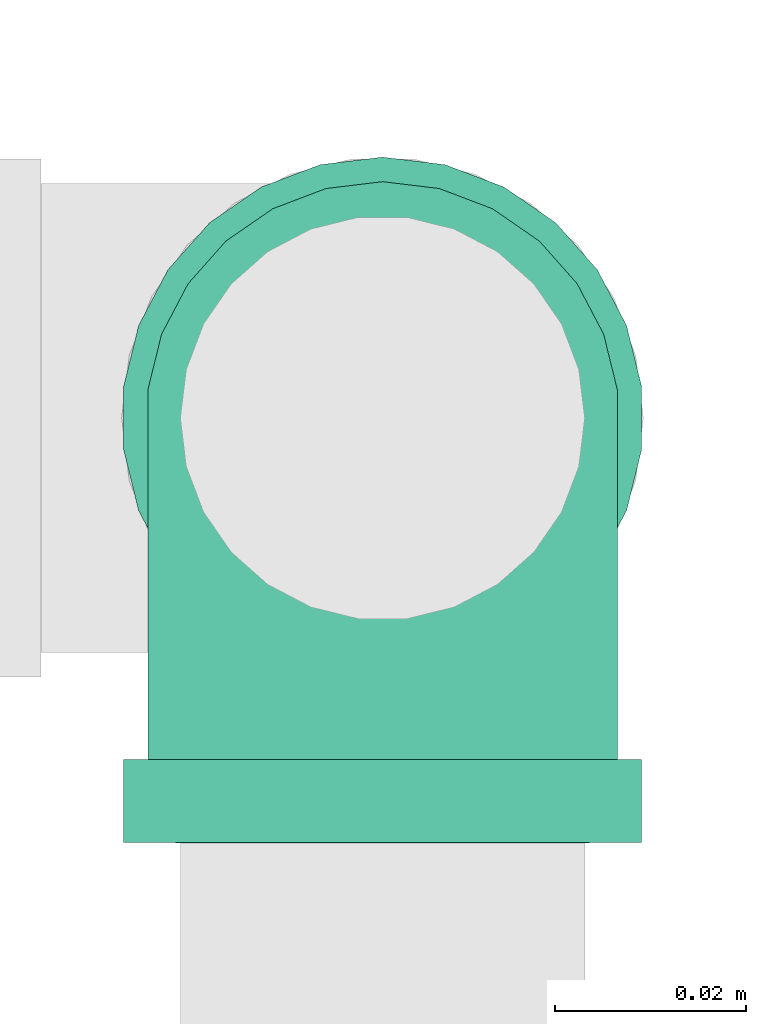
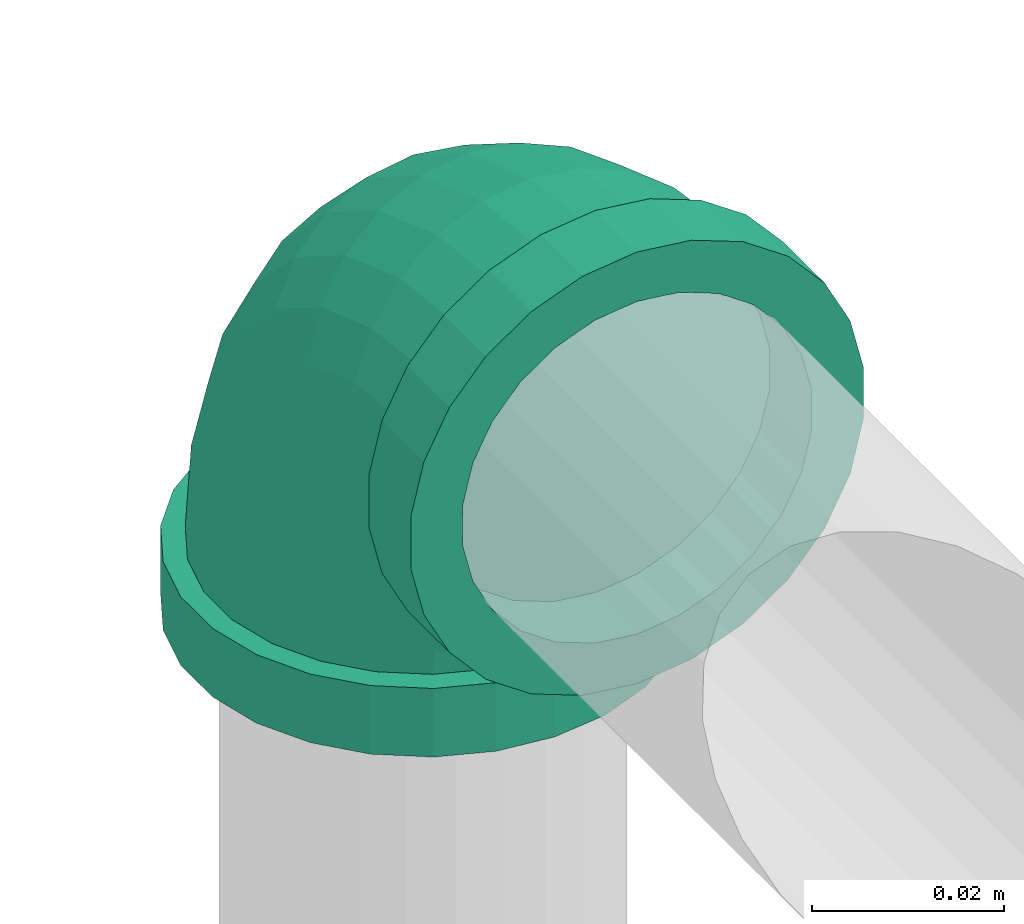
# One storey, part 5 of 7: 1 pipe fitting.
"""IFC4 building model written with IfcOpenShell, lengths in millimetres."""

from ifc_helpers import new_model, entity, si_unit, converted_unit, derived_unit, direction, frame, origin, place, context, subcontext, project, spatial, source, transform, mapped, type_object, type_shapes, element, save


model = new_model("IFC4")

# Units and contexts
model_context = context("Model", 3, precision=0.01, world=origin(), true_north=direction((6.12303176911189e-17, 1.0)))
body_context = subcontext(model_context, "Body", "Model", "MODEL_VIEW")
ifc_project = project(units=[si_unit("LENGTHUNIT", "METRE", prefix="MILLI"), si_unit("AREAUNIT", "SQUARE_METRE"), si_unit("VOLUMEUNIT", "CUBIC_METRE"), converted_unit("PLANEANGLEUNIT", "DEGREE", entity("IfcRatioMeasure", 0.0174532925199433), si_unit("PLANEANGLEUNIT", "RADIAN"), dimensions=[0, 0, 0, 0, 0, 0, 0]), si_unit("MASSUNIT", "GRAM", prefix="KILO"), derived_unit("MASSDENSITYUNIT", [(si_unit("MASSUNIT", "GRAM", prefix="KILO"), 1), (si_unit("LENGTHUNIT", "METRE"), -3)]), derived_unit("MOMENTOFINERTIAUNIT", [(si_unit("LENGTHUNIT", "METRE"), 4)]), si_unit("TIMEUNIT", "SECOND"), si_unit("FREQUENCYUNIT", "HERTZ"), si_unit("THERMODYNAMICTEMPERATUREUNIT", "DEGREE_CELSIUS"), derived_unit("THERMALTRANSMITTANCEUNIT", [(si_unit("MASSUNIT", "GRAM", prefix="KILO"), 1), (si_unit("THERMODYNAMICTEMPERATUREUNIT", "KELVIN"), -1), (si_unit("TIMEUNIT", "SECOND"), -3)]), derived_unit("VOLUMETRICFLOWRATEUNIT", [(si_unit("LENGTHUNIT", "METRE"), 3), (si_unit("TIMEUNIT", "SECOND"), -1)]), si_unit("ELECTRICCURRENTUNIT", "AMPERE"), si_unit("ELECTRICVOLTAGEUNIT", "VOLT"), si_unit("POWERUNIT", "WATT"), si_unit("FORCEUNIT", "NEWTON", prefix="KILO"), si_unit("ILLUMINANCEUNIT", "LUX"), si_unit("LUMINOUSFLUXUNIT", "LUMEN"), si_unit("LUMINOUSINTENSITYUNIT", "CANDELA"), derived_unit("USERDEFINED", [(si_unit("MASSUNIT", "GRAM", prefix="KILO"), -1), (si_unit("LENGTHUNIT", "METRE"), -2), (si_unit("TIMEUNIT", "SECOND"), 3), (si_unit("LUMINOUSFLUXUNIT", "LUMEN"), 1)]), derived_unit("LINEARVELOCITYUNIT", [(si_unit("LENGTHUNIT", "METRE"), 1), (si_unit("TIMEUNIT", "SECOND"), -1)]), si_unit("PRESSUREUNIT", "PASCAL"), derived_unit("USERDEFINED", [(si_unit("LENGTHUNIT", "METRE"), -2), (si_unit("MASSUNIT", "GRAM", prefix="KILO"), 1), (si_unit("TIMEUNIT", "SECOND"), -2)]), derived_unit("LINEARFORCEUNIT", [(si_unit("MASSUNIT", "GRAM", prefix="KILO"), 1), (si_unit("LENGTHUNIT", "METRE"), 1), (si_unit("TIMEUNIT", "SECOND"), -2), (si_unit("LENGTHUNIT", "METRE"), -1)]), derived_unit("PLANARFORCEUNIT", [(si_unit("MASSUNIT", "GRAM", prefix="KILO"), 1), (si_unit("LENGTHUNIT", "METRE"), 1), (si_unit("TIMEUNIT", "SECOND"), -2), (si_unit("LENGTHUNIT", "METRE"), -2)])], contexts=[model_context])

# Site, building, storey
site_placement = place(None, origin())
site = spatial("IfcSite", under=ifc_project, at=site_placement, CompositionType="ELEMENT")
building_placement = place(site_placement, origin())
building = spatial("IfcBuilding", under=site, at=building_placement, CompositionType="ELEMENT")
storey_placement = place(building_placement, origin())
storey = spatial("IfcBuildingStorey", under=building, at=storey_placement, Name="Ebene 1", CompositionType="ELEMENT", Elevation=0.0)

# Pipe fitting
pipe_fitting_type = type_object("IfcPipeFittingType", Name="Threaded - Elbow - MI - Class 1:Standard 4", PredefinedType="NOTDEFINED")
cartesian_point_1 = entity("IfcCartesianPoint", [-44.4999999999936, -27.3500000000084, 0.0])
vertex_point_1 = entity("IfcVertexPoint", cartesian_point_1)
cartesian_point_2 = entity("IfcCartesianPoint", [-44.4999999999936, 27.3499999999916, 0.0])
vertex_point_2 = entity("IfcVertexPoint", cartesian_point_2)
cartesian_point_3 = entity("IfcCartesianPoint", [-44.4999999999936, 0.0, 0.0])
ifc_direction_1 = entity("IfcDirection", [-1.0, 0.0, 0.0])
ifc_direction_2 = entity("IfcDirection", [0.0, 1.0, 0.0])
edge_curve_1 = entity("IfcEdgeCurve", vertex_point_1, vertex_point_2, entity("IfcTrimmedCurve", entity("IfcCircle", entity("IfcAxis2Placement3D", cartesian_point_3, ifc_direction_1, ifc_direction_2), 27.35), [cartesian_point_1], [cartesian_point_2], True, "CARTESIAN"), True)
edge_curve_2 = entity("IfcEdgeCurve", vertex_point_2, vertex_point_1, entity("IfcTrimmedCurve", entity("IfcCircle", entity("IfcAxis2Placement3D", cartesian_point_3, ifc_direction_1, ifc_direction_2), 27.35), [cartesian_point_2], [cartesian_point_1], True, "CARTESIAN"), True)
cartesian_point_4 = entity("IfcCartesianPoint", [-44.4999999999936, 21.0819999999918, 0.0])
vertex_point_3 = entity("IfcVertexPoint", cartesian_point_4)
cartesian_point_5 = entity("IfcCartesianPoint", [-44.4999999999936, -21.0820000000082, 0.0])
vertex_point_4 = entity("IfcVertexPoint", cartesian_point_5)
ifc_direction_3 = entity("IfcDirection", [1.0, 0.0, 0.0])
edge_curve_3 = entity("IfcEdgeCurve", vertex_point_3, vertex_point_4, entity("IfcTrimmedCurve", entity("IfcCircle", entity("IfcAxis2Placement3D", cartesian_point_3, ifc_direction_3, ifc_direction_2), 21.082), [cartesian_point_4], [cartesian_point_5], True, "CARTESIAN"), True)
edge_curve_4 = entity("IfcEdgeCurve", vertex_point_4, vertex_point_3, entity("IfcTrimmedCurve", entity("IfcCircle", entity("IfcAxis2Placement3D", cartesian_point_3, ifc_direction_3, ifc_direction_2), 21.082), [cartesian_point_5], [cartesian_point_4], True, "CARTESIAN"), True)
ifc_direction_4 = entity("IfcDirection", [0.0, 0.0, 1.0])
cartesian_point_6 = entity("IfcCartesianPoint", [-35.7999999999934, 27.3499999999916, 0.0])
vertex_point_5 = entity("IfcVertexPoint", cartesian_point_6)
cartesian_point_7 = entity("IfcCartesianPoint", [-35.7999999999934, -27.3500000000084, 0.0])
vertex_point_6 = entity("IfcVertexPoint", cartesian_point_7)
cartesian_point_8 = entity("IfcCartesianPoint", [-35.7999999999934, 0.0, 0.0])
edge_curve_5 = entity("IfcEdgeCurve", vertex_point_5, vertex_point_6, entity("IfcTrimmedCurve", entity("IfcCircle", entity("IfcAxis2Placement3D", cartesian_point_8, ifc_direction_3, ifc_direction_2), 27.35), [cartesian_point_6], [cartesian_point_7], True, "CARTESIAN"), True)
edge_curve_6 = entity("IfcEdgeCurve", vertex_point_6, vertex_point_5, entity("IfcTrimmedCurve", entity("IfcCircle", entity("IfcAxis2Placement3D", cartesian_point_8, ifc_direction_3, ifc_direction_2), 27.35), [cartesian_point_7], [cartesian_point_6], True, "CARTESIAN"), True)
cartesian_point_9 = entity("IfcCartesianPoint", [-35.7999999999934, -24.7800000000084, 0.0])
vertex_point_7 = entity("IfcVertexPoint", cartesian_point_9)
cartesian_point_10 = entity("IfcCartesianPoint", [-35.7999999999934, 24.7799999999916, 0.0])
vertex_point_8 = entity("IfcVertexPoint", cartesian_point_10)
edge_curve_7 = entity("IfcEdgeCurve", vertex_point_7, vertex_point_8, entity("IfcTrimmedCurve", entity("IfcCircle", entity("IfcAxis2Placement3D", cartesian_point_8, ifc_direction_1, ifc_direction_2), 24.78), [cartesian_point_9], [cartesian_point_10], True, "CARTESIAN"), True)
edge_curve_8 = entity("IfcEdgeCurve", vertex_point_8, vertex_point_7, entity("IfcTrimmedCurve", entity("IfcCircle", entity("IfcAxis2Placement3D", cartesian_point_8, ifc_direction_1, ifc_direction_2), 24.78), [cartesian_point_10], [cartesian_point_9], True, "CARTESIAN"), True)
edge_curve_9 = entity("IfcEdgeCurve", vertex_point_1, vertex_point_6, entity("IfcTrimmedCurve", entity("IfcLine", cartesian_point_1, entity("IfcVector", ifc_direction_3, 304.8)), [cartesian_point_1], [cartesian_point_7], True, "CARTESIAN"), True)
edge_curve_10 = entity("IfcEdgeCurve", vertex_point_5, vertex_point_2, entity("IfcTrimmedCurve", entity("IfcLine", cartesian_point_2, entity("IfcVector", ifc_direction_1, 304.8)), [cartesian_point_6], [cartesian_point_2], True, "CARTESIAN"), True)
cartesian_point_11 = entity("IfcCartesianPoint", [-35.7999999999935, 21.0819999999918, 0.0])
vertex_point_9 = entity("IfcVertexPoint", cartesian_point_11)
edge_curve_11 = entity("IfcEdgeCurve", vertex_point_3, vertex_point_9, entity("IfcTrimmedCurve", entity("IfcLine", cartesian_point_11, entity("IfcVector", ifc_direction_3, 304.8)), [cartesian_point_4], [cartesian_point_11], True, "CARTESIAN"), True)
cartesian_point_12 = entity("IfcCartesianPoint", [-35.7999999999934, -21.0820000000082, 0.0])
vertex_point_10 = entity("IfcVertexPoint", cartesian_point_12)
edge_curve_12 = entity("IfcEdgeCurve", vertex_point_9, vertex_point_10, entity("IfcTrimmedCurve", entity("IfcCircle", entity("IfcAxis2Placement3D", cartesian_point_8, ifc_direction_3, ifc_direction_2), 21.082), [cartesian_point_11], [cartesian_point_12], True, "CARTESIAN"), True)
edge_curve_13 = entity("IfcEdgeCurve", vertex_point_10, vertex_point_4, entity("IfcTrimmedCurve", entity("IfcLine", cartesian_point_12, entity("IfcVector", ifc_direction_1, 304.8)), [cartesian_point_12], [cartesian_point_5], True, "CARTESIAN"), True)
cartesian_point_13 = entity("IfcCartesianPoint", [-27.0374999999917, 0.0, 0.0])
edge_curve_14 = entity("IfcEdgeCurve", vertex_point_10, vertex_point_9, entity("IfcTrimmedCurve", entity("IfcCircle", entity("IfcAxis2Placement3D", cartesian_point_8, ifc_direction_3, ifc_direction_2), 21.082), [cartesian_point_12], [cartesian_point_11], True, "CARTESIAN"), True)
cartesian_point_14 = entity("IfcCartesianPoint", [27.386875344551, 35.7717983733246, 0.0])
vertex_point_11 = entity("IfcVertexPoint", cartesian_point_14)
cartesian_point_15 = entity("IfcCartesianPoint", [-27.3130956148533, 35.82816361374, 0.0])
vertex_point_12 = entity("IfcVertexPoint", cartesian_point_15)
cartesian_point_16 = entity("IfcCartesianPoint", [0.036889864848809, 35.7999809935323, 0.0])
edge_curve_15 = entity("IfcEdgeCurve", vertex_point_11, vertex_point_12, entity("IfcTrimmedCurve", entity("IfcCircle", entity("IfcAxis2Placement3D", cartesian_point_16, entity("IfcDirection", [-0.00103044315202008, -0.999999469093314, 0.0]), entity("IfcDirection", [-0.999999469093314, 0.00103044315202008, 0.0])), 27.35), [cartesian_point_14], [cartesian_point_15], True, "CARTESIAN"), True)
edge_curve_16 = entity("IfcEdgeCurve", vertex_point_12, vertex_point_11, entity("IfcTrimmedCurve", entity("IfcCircle", entity("IfcAxis2Placement3D", cartesian_point_16, entity("IfcDirection", [-0.00103044315202008, -0.999999469093314, 0.0]), entity("IfcDirection", [-0.999999469093314, 0.00103044315202008, 0.0])), 27.35), [cartesian_point_15], [cartesian_point_14], True, "CARTESIAN"), True)
cartesian_point_17 = entity("IfcCartesianPoint", [-24.7430969792835, 35.8255153748394, 0.0])
vertex_point_13 = entity("IfcVertexPoint", cartesian_point_17)
cartesian_point_18 = entity("IfcCartesianPoint", [24.8168767089811, 35.7744466122252, 0.0])
vertex_point_14 = entity("IfcVertexPoint", cartesian_point_18)
edge_curve_17 = entity("IfcEdgeCurve", vertex_point_13, vertex_point_14, entity("IfcTrimmedCurve", entity("IfcCircle", entity("IfcAxis2Placement3D", cartesian_point_16, entity("IfcDirection", [0.00103044315201795, 0.999999469093314, 0.0]), entity("IfcDirection", [-0.999999469093314, 0.00103044315201795, 0.0])), 24.78), [cartesian_point_17], [cartesian_point_18], True, "CARTESIAN"), True)
edge_curve_18 = entity("IfcEdgeCurve", vertex_point_14, vertex_point_13, entity("IfcTrimmedCurve", entity("IfcCircle", entity("IfcAxis2Placement3D", cartesian_point_16, entity("IfcDirection", [0.00103044315201795, 0.999999469093314, 0.0]), entity("IfcDirection", [-0.999999469093314, 0.00103044315201795, 0.0])), 24.78), [cartesian_point_18], [cartesian_point_17], True, "CARTESIAN"), True)
cartesian_point_19 = entity("IfcCartesianPoint", [-27.3041307594308, 44.5281589948519, 0.0])
vertex_point_15 = entity("IfcVertexPoint", cartesian_point_19)
cartesian_point_20 = entity("IfcCartesianPoint", [27.3958401999735, 44.4717937544364, 0.0])
vertex_point_16 = entity("IfcVertexPoint", cartesian_point_20)
cartesian_point_21 = entity("IfcCartesianPoint", [0.0458547202713837, 44.4999763746441, 0.0])
edge_curve_19 = entity("IfcEdgeCurve", vertex_point_15, vertex_point_16, entity("IfcTrimmedCurve", entity("IfcCircle", entity("IfcAxis2Placement3D", cartesian_point_21, entity("IfcDirection", [0.00103044315202008, 0.999999469093314, 0.0]), entity("IfcDirection", [-0.999999469093314, 0.00103044315202008, 0.0])), 27.35), [cartesian_point_19], [cartesian_point_20], True, "CARTESIAN"), True)
edge_curve_20 = entity("IfcEdgeCurve", vertex_point_16, vertex_point_15, entity("IfcTrimmedCurve", entity("IfcCircle", entity("IfcAxis2Placement3D", cartesian_point_21, entity("IfcDirection", [0.00103044315202008, 0.999999469093314, 0.0]), entity("IfcDirection", [-0.999999469093314, 0.00103044315202008, 0.0])), 27.35), [cartesian_point_20], [cartesian_point_19], True, "CARTESIAN"), True)
cartesian_point_22 = entity("IfcCartesianPoint", [0.0458547202374063, 44.4999763746442, -21.081999999986])
vertex_point_17 = entity("IfcVertexPoint", cartesian_point_22)
cartesian_point_23 = entity("IfcCartesianPoint", [0.0458547202372113, 44.4999763746442, 21.082000000014])
vertex_point_18 = entity("IfcVertexPoint", cartesian_point_23)
ifc_direction_5 = entity("IfcDirection", [0.0, 0.0, -1.0])
edge_curve_21 = entity("IfcEdgeCurve", vertex_point_17, vertex_point_18, entity("IfcTrimmedCurve", entity("IfcCircle", entity("IfcAxis2Placement3D", cartesian_point_21, entity("IfcDirection", [-0.00103044315202008, -0.999999469093314, 0.0]), ifc_direction_5), 21.082), [cartesian_point_22], [cartesian_point_23], True, "CARTESIAN"), True)
edge_curve_22 = entity("IfcEdgeCurve", vertex_point_18, vertex_point_17, entity("IfcTrimmedCurve", entity("IfcCircle", entity("IfcAxis2Placement3D", cartesian_point_21, entity("IfcDirection", [-0.00103044315202008, -0.999999469093314, 0.0]), ifc_direction_5), 21.082), [cartesian_point_23], [cartesian_point_22], True, "CARTESIAN"), True)
edge_curve_23 = entity("IfcEdgeCurve", vertex_point_11, vertex_point_16, entity("IfcTrimmedCurve", entity("IfcLine", cartesian_point_14, entity("IfcVector", entity("IfcDirection", [0.00103044315202008, 0.999999469093314, 0.0]), 304.8)), [cartesian_point_14], [cartesian_point_20], True, "CARTESIAN"), True)
edge_curve_24 = entity("IfcEdgeCurve", vertex_point_15, vertex_point_12, entity("IfcTrimmedCurve", entity("IfcLine", cartesian_point_15, entity("IfcVector", entity("IfcDirection", [-0.00103044315202008, -0.999999469093314, 0.0]), 304.8)), [cartesian_point_19], [cartesian_point_15], True, "CARTESIAN"), True)
cartesian_point_24 = entity("IfcCartesianPoint", [0.0368898648152249, 35.7999809935323, -21.081999999986])
vertex_point_19 = entity("IfcVertexPoint", cartesian_point_24)
edge_curve_25 = entity("IfcEdgeCurve", vertex_point_17, vertex_point_19, entity("IfcTrimmedCurve", entity("IfcLine", cartesian_point_24, entity("IfcVector", entity("IfcDirection", [-0.00103044315202008, -0.999999469093314, 0.0]), 304.8)), [cartesian_point_22], [cartesian_point_24], True, "CARTESIAN"), True)
cartesian_point_25 = entity("IfcCartesianPoint", [0.0368898648146367, 35.7999809935323, 21.082000000014])
vertex_point_20 = entity("IfcVertexPoint", cartesian_point_25)
edge_curve_26 = entity("IfcEdgeCurve", vertex_point_19, vertex_point_20, entity("IfcTrimmedCurve", entity("IfcCircle", entity("IfcAxis2Placement3D", cartesian_point_16, entity("IfcDirection", [-0.00103044315202008, -0.999999469093314, 0.0]), ifc_direction_5), 21.082), [cartesian_point_24], [cartesian_point_25], True, "CARTESIAN"), True)
edge_curve_27 = entity("IfcEdgeCurve", vertex_point_20, vertex_point_18, entity("IfcTrimmedCurve", entity("IfcLine", cartesian_point_25, entity("IfcVector", entity("IfcDirection", [0.00103044315202008, 0.999999469093314, 0.0]), 304.8)), [cartesian_point_25], [cartesian_point_23], True, "CARTESIAN"), True)
cartesian_point_26 = entity("IfcCartesianPoint", [0.0278606066951176, 27.0374856456003, 0.0])
edge_curve_28 = entity("IfcEdgeCurve", vertex_point_20, vertex_point_19, entity("IfcTrimmedCurve", entity("IfcCircle", entity("IfcAxis2Placement3D", cartesian_point_16, entity("IfcDirection", [-0.00103044315202008, -0.999999469093314, 0.0]), ifc_direction_5), 21.082), [cartesian_point_25], [cartesian_point_24], True, "CARTESIAN"), True)
cartesian_point_27 = entity("IfcCartesianPoint", [-35.7999999999935, 35.8369088908884, 0.0])
ifc_direction_6 = entity("IfcDirection", [0.0, -1.0, 0.0])
edge_curve_29 = entity("IfcEdgeCurve", vertex_point_13, vertex_point_8, entity("IfcTrimmedCurve", entity("IfcCircle", entity("IfcAxis2Placement3D", cartesian_point_27, ifc_direction_5, ifc_direction_6), 11.0569088908968), [cartesian_point_17], [cartesian_point_10], True, "CARTESIAN"), True)
edge_curve_30 = entity("IfcEdgeCurve", vertex_point_7, vertex_point_14, entity("IfcTrimmedCurve", entity("IfcCircle", entity("IfcAxis2Placement3D", cartesian_point_27, ifc_direction_4, ifc_direction_6), 60.6169088908968), [cartesian_point_9], [cartesian_point_18], True, "CARTESIAN"), True)
cartesian_point_28 = entity("IfcCartesianPoint", [0.0369088909033348, 35.8369088908884, 0.0])
cartesian_point_29 = entity("IfcCartesianPoint", [24.8169088909033, 35.8369088908884, 0.0])
cartesian_point_30 = entity("IfcCartesianPoint", [-24.7430911090967, 35.8369088908884, 0.0])
shared_shape = source(origin(), body_context, "Body", "AdvancedBrep", [
    entity("IfcAdvancedBrep", entity("IfcClosedShell", [entity("IfcAdvancedFace", [entity("IfcFaceOuterBound", entity("IfcEdgeLoop", [entity("IfcOrientedEdge", None, None, edge_curve_1, True), entity("IfcOrientedEdge", None, None, edge_curve_2, True)]), True), entity("IfcFaceBound", entity("IfcEdgeLoop", [entity("IfcOrientedEdge", None, None, edge_curve_3, True), entity("IfcOrientedEdge", None, None, edge_curve_4, True)]), False)], entity("IfcPlane", entity("IfcAxis2Placement3D", cartesian_point_3, ifc_direction_1, ifc_direction_4)), True), entity("IfcAdvancedFace", [entity("IfcFaceOuterBound", entity("IfcEdgeLoop", [entity("IfcOrientedEdge", None, None, edge_curve_5, True), entity("IfcOrientedEdge", None, None, edge_curve_6, True)]), True), entity("IfcFaceBound", entity("IfcEdgeLoop", [entity("IfcOrientedEdge", None, None, edge_curve_7, True), entity("IfcOrientedEdge", None, None, edge_curve_8, True)]), False)], entity("IfcPlane", entity("IfcAxis2Placement3D", cartesian_point_8, ifc_direction_3, ifc_direction_4)), True), entity("IfcAdvancedFace", [entity("IfcFaceOuterBound", entity("IfcEdgeLoop", [entity("IfcOrientedEdge", None, None, edge_curve_1, False), entity("IfcOrientedEdge", None, None, edge_curve_9, True), entity("IfcOrientedEdge", None, None, edge_curve_5, False), entity("IfcOrientedEdge", None, None, edge_curve_10, True)]), True)], entity("IfcCylindricalSurface", entity("IfcAxis2Placement3D", cartesian_point_3, ifc_direction_1, ifc_direction_2), 27.35), True), entity("IfcAdvancedFace", [entity("IfcFaceOuterBound", entity("IfcEdgeLoop", [entity("IfcOrientedEdge", None, None, edge_curve_2, False), entity("IfcOrientedEdge", None, None, edge_curve_10, False), entity("IfcOrientedEdge", None, None, edge_curve_6, False), entity("IfcOrientedEdge", None, None, edge_curve_9, False)]), True)], entity("IfcCylindricalSurface", entity("IfcAxis2Placement3D", cartesian_point_3, ifc_direction_1, ifc_direction_2), 27.35), True), entity("IfcAdvancedFace", [entity("IfcFaceOuterBound", entity("IfcEdgeLoop", [entity("IfcOrientedEdge", None, None, edge_curve_3, False), entity("IfcOrientedEdge", None, None, edge_curve_11, True), entity("IfcOrientedEdge", None, None, edge_curve_12, True), entity("IfcOrientedEdge", None, None, edge_curve_13, True)]), True)], entity("IfcCylindricalSurface", entity("IfcAxis2Placement3D", cartesian_point_13, ifc_direction_1, ifc_direction_2), 21.082), False), entity("IfcAdvancedFace", [entity("IfcFaceOuterBound", entity("IfcEdgeLoop", [entity("IfcOrientedEdge", None, None, edge_curve_4, False), entity("IfcOrientedEdge", None, None, edge_curve_13, False), entity("IfcOrientedEdge", None, None, edge_curve_14, True), entity("IfcOrientedEdge", None, None, edge_curve_11, False)]), True)], entity("IfcCylindricalSurface", entity("IfcAxis2Placement3D", cartesian_point_13, ifc_direction_1, ifc_direction_2), 21.082), False), entity("IfcAdvancedFace", [entity("IfcFaceOuterBound", entity("IfcEdgeLoop", [entity("IfcOrientedEdge", None, None, edge_curve_15, True), entity("IfcOrientedEdge", None, None, edge_curve_16, True)]), True), entity("IfcFaceBound", entity("IfcEdgeLoop", [entity("IfcOrientedEdge", None, None, edge_curve_17, True), entity("IfcOrientedEdge", None, None, edge_curve_18, True)]), False)], entity("IfcPlane", entity("IfcAxis2Placement3D", cartesian_point_16, entity("IfcDirection", [-0.00103044315202008, -0.999999469093314, 0.0]), ifc_direction_4)), True), entity("IfcAdvancedFace", [entity("IfcFaceOuterBound", entity("IfcEdgeLoop", [entity("IfcOrientedEdge", None, None, edge_curve_19, True), entity("IfcOrientedEdge", None, None, edge_curve_20, True)]), True), entity("IfcFaceBound", entity("IfcEdgeLoop", [entity("IfcOrientedEdge", None, None, edge_curve_21, True), entity("IfcOrientedEdge", None, None, edge_curve_22, True)]), False)], entity("IfcPlane", entity("IfcAxis2Placement3D", cartesian_point_21, entity("IfcDirection", [0.00103044315202008, 0.999999469093314, 0.0]), ifc_direction_4)), True), entity("IfcAdvancedFace", [entity("IfcFaceOuterBound", entity("IfcEdgeLoop", [entity("IfcOrientedEdge", None, None, edge_curve_15, False), entity("IfcOrientedEdge", None, None, edge_curve_23, True), entity("IfcOrientedEdge", None, None, edge_curve_19, False), entity("IfcOrientedEdge", None, None, edge_curve_24, True)]), True)], entity("IfcCylindricalSurface", entity("IfcAxis2Placement3D", cartesian_point_16, entity("IfcDirection", [-0.00103044315202008, -0.999999469093314, 0.0]), entity("IfcDirection", [-0.999999469093314, 0.00103044315202008, 0.0])), 27.35), True), entity("IfcAdvancedFace", [entity("IfcFaceOuterBound", entity("IfcEdgeLoop", [entity("IfcOrientedEdge", None, None, edge_curve_16, False), entity("IfcOrientedEdge", None, None, edge_curve_24, False), entity("IfcOrientedEdge", None, None, edge_curve_20, False), entity("IfcOrientedEdge", None, None, edge_curve_23, False)]), True)], entity("IfcCylindricalSurface", entity("IfcAxis2Placement3D", cartesian_point_16, entity("IfcDirection", [-0.00103044315202008, -0.999999469093314, 0.0]), entity("IfcDirection", [-0.999999469093314, 0.00103044315202008, 0.0])), 27.35), True), entity("IfcAdvancedFace", [entity("IfcFaceOuterBound", entity("IfcEdgeLoop", [entity("IfcOrientedEdge", None, None, edge_curve_21, False), entity("IfcOrientedEdge", None, None, edge_curve_25, True), entity("IfcOrientedEdge", None, None, edge_curve_26, True), entity("IfcOrientedEdge", None, None, edge_curve_27, True)]), True)], entity("IfcCylindricalSurface", entity("IfcAxis2Placement3D", cartesian_point_26, entity("IfcDirection", [0.00103044315202008, 0.999999469093314, 0.0]), ifc_direction_5), 21.082), False), entity("IfcAdvancedFace", [entity("IfcFaceOuterBound", entity("IfcEdgeLoop", [entity("IfcOrientedEdge", None, None, edge_curve_22, False), entity("IfcOrientedEdge", None, None, edge_curve_27, False), entity("IfcOrientedEdge", None, None, edge_curve_28, True), entity("IfcOrientedEdge", None, None, edge_curve_25, False)]), True)], entity("IfcCylindricalSurface", entity("IfcAxis2Placement3D", cartesian_point_26, entity("IfcDirection", [0.00103044315202008, 0.999999469093314, 0.0]), ifc_direction_5), 21.082), False), entity("IfcAdvancedFace", [entity("IfcFaceOuterBound", entity("IfcEdgeLoop", [entity("IfcOrientedEdge", None, None, edge_curve_12, False), entity("IfcOrientedEdge", None, None, edge_curve_14, False)]), True)], entity("IfcPlane", entity("IfcAxis2Placement3D", cartesian_point_8, ifc_direction_1, ifc_direction_4)), True), entity("IfcAdvancedFace", [entity("IfcFaceOuterBound", entity("IfcEdgeLoop", [entity("IfcOrientedEdge", None, None, edge_curve_26, False), entity("IfcOrientedEdge", None, None, edge_curve_28, False)]), True)], entity("IfcPlane", entity("IfcAxis2Placement3D", cartesian_point_16, entity("IfcDirection", [0.001030443152018, 0.999999469093314, 0.0]), ifc_direction_4)), True), entity("IfcAdvancedFace", [entity("IfcFaceOuterBound", entity("IfcEdgeLoop", [entity("IfcOrientedEdge", None, None, edge_curve_29, True), entity("IfcOrientedEdge", None, None, edge_curve_7, False), entity("IfcOrientedEdge", None, None, edge_curve_30, True), entity("IfcOrientedEdge", None, None, edge_curve_17, False)]), True)], entity("IfcSurfaceOfRevolution", entity("IfcArbitraryOpenProfileDef", "CURVE", None, entity("IfcTrimmedCurve", entity("IfcCircle", entity("IfcAxis2Placement3D", cartesian_point_28, ifc_direction_6, ifc_direction_1), 24.78), [cartesian_point_29], [cartesian_point_30], True, "CARTESIAN")), None, entity("IfcAxis1Placement", cartesian_point_27, ifc_direction_4)), True), entity("IfcAdvancedFace", [entity("IfcFaceOuterBound", entity("IfcEdgeLoop", [entity("IfcOrientedEdge", None, None, edge_curve_29, False), entity("IfcOrientedEdge", None, None, edge_curve_18, False), entity("IfcOrientedEdge", None, None, edge_curve_30, False), entity("IfcOrientedEdge", None, None, edge_curve_8, False)]), True)], entity("IfcSurfaceOfRevolution", entity("IfcArbitraryOpenProfileDef", "CURVE", None, entity("IfcTrimmedCurve", entity("IfcCircle", entity("IfcAxis2Placement3D", cartesian_point_28, ifc_direction_6, ifc_direction_1), 24.78), [cartesian_point_30], [cartesian_point_29], True, "CARTESIAN")), None, entity("IfcAxis1Placement", cartesian_point_27, ifc_direction_4)), True)])),
])
type_shapes(pipe_fitting_type, [shared_shape])
pipe_fitting_placement = place(storey_placement, frame((10527.7791757465, 95470.2511574744, 3633.32755899046), z_axis=(-1.0, 0.0, 0.0), x_axis=(0.0, 0.999999469093314, -0.00103044315202005)))
element("IfcPipeFitting", 1, at=pipe_fitting_placement, inside=storey, type_object=pipe_fitting_type, Name="Threaded - Elbow - MI - Class 1:Standard 4:2582", ObjectType="Threaded - Elbow - MI - Class 1:Standard 4", PredefinedType="NOTDEFINED", context=body_context, shape_type="MappedRepresentation", body=[
    mapped(shared_shape, transform((0.0, 0.0, 0.0), scale=1.0)),
])

save(model, "model.ifc")
